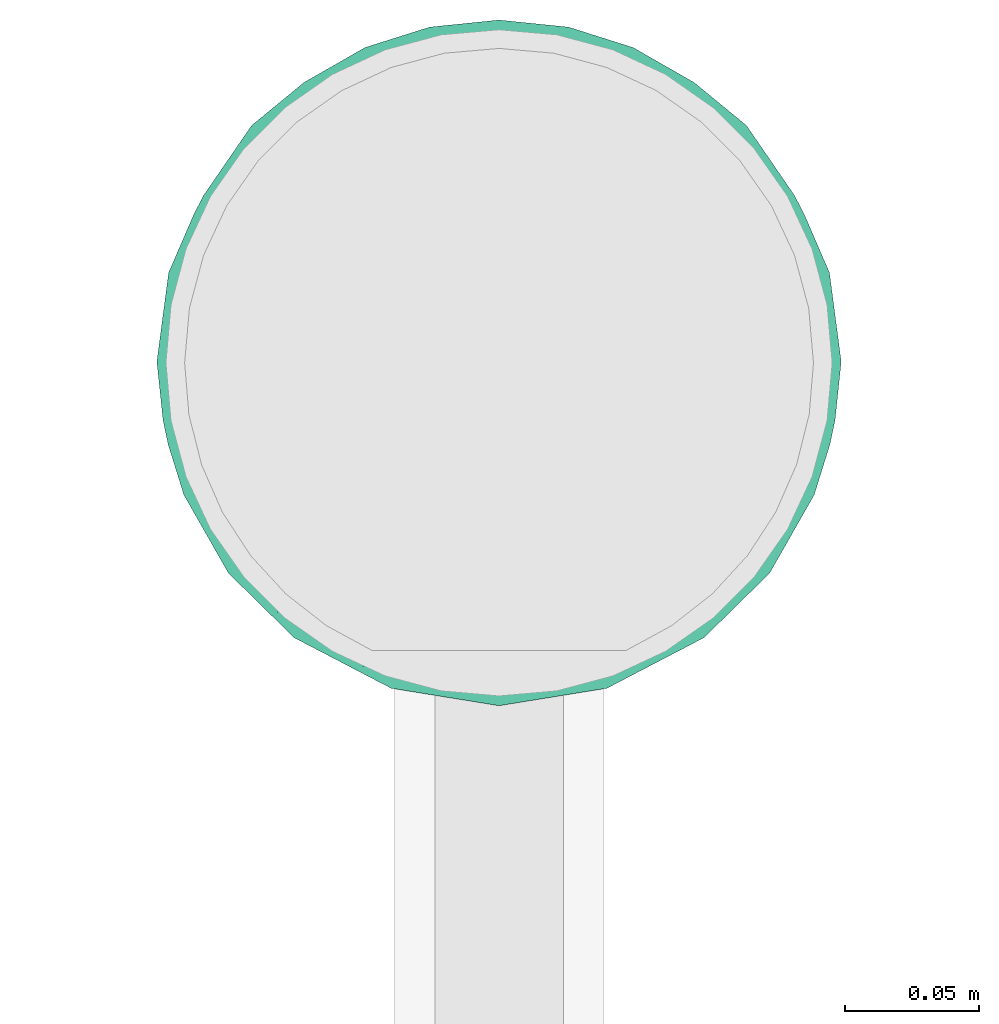
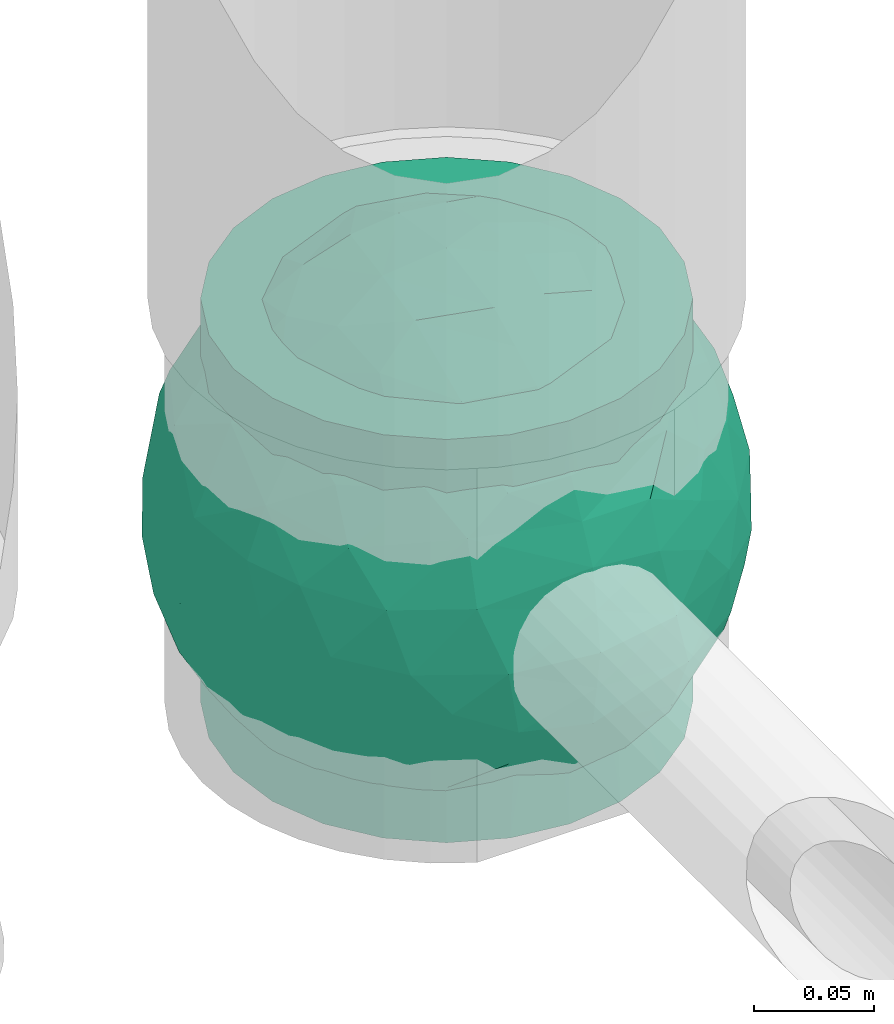
# One storey, part 34 of 39: 1 flow fitting.
"""IFC2X3 building model written with IfcOpenShell, lengths in millimetres."""

from ifc_helpers import new_model, entity, si_unit, converted_unit, derived_unit, direction, frame, origin, place, context, subcontext, project, spatial, faceted_brep, source, transform, mapped, material, material_list, type_object, type_shapes, element, save


model = new_model("IFC2X3")

# Units and contexts
model_context = context("Model", 3, precision=0.01, world=origin(), true_north=direction((6.12303176911189e-17, 1.0)))
body_context = subcontext(model_context, "Body", "Model", "MODEL_VIEW")
ifc_project = project(units=[si_unit("LENGTHUNIT", "METRE", prefix="MILLI"), si_unit("AREAUNIT", "SQUARE_METRE"), si_unit("VOLUMEUNIT", "CUBIC_METRE"), converted_unit("PLANEANGLEUNIT", "DEGREE", entity("IfcRatioMeasure", 0.0174532925199433), si_unit("PLANEANGLEUNIT", "RADIAN"), dimensions=[0, 0, 0, 0, 0, 0, 0]), si_unit("MASSUNIT", "GRAM", prefix="KILO"), derived_unit("MASSDENSITYUNIT", [(si_unit("MASSUNIT", "GRAM", prefix="KILO"), 1), (si_unit("LENGTHUNIT", "METRE"), -3)]), derived_unit("MOMENTOFINERTIAUNIT", [(si_unit("LENGTHUNIT", "METRE"), 4)]), si_unit("TIMEUNIT", "SECOND"), si_unit("FREQUENCYUNIT", "HERTZ"), si_unit("THERMODYNAMICTEMPERATUREUNIT", "DEGREE_CELSIUS"), derived_unit("THERMALTRANSMITTANCEUNIT", [(si_unit("MASSUNIT", "GRAM", prefix="KILO"), 1), (si_unit("THERMODYNAMICTEMPERATUREUNIT", "KELVIN"), -1), (si_unit("TIMEUNIT", "SECOND"), -3)]), derived_unit("VOLUMETRICFLOWRATEUNIT", [(si_unit("LENGTHUNIT", "METRE"), 3), (si_unit("TIMEUNIT", "SECOND"), -1)]), derived_unit("MASSFLOWRATEUNIT", [(si_unit("MASSUNIT", "GRAM", prefix="KILO"), 1), (si_unit("TIMEUNIT", "SECOND"), -1)]), derived_unit("ROTATIONALFREQUENCYUNIT", [(si_unit("TIMEUNIT", "SECOND"), -1)]), si_unit("ELECTRICCURRENTUNIT", "AMPERE"), si_unit("ELECTRICVOLTAGEUNIT", "VOLT"), si_unit("POWERUNIT", "WATT"), si_unit("FORCEUNIT", "NEWTON", prefix="KILO"), si_unit("ILLUMINANCEUNIT", "LUX"), si_unit("LUMINOUSFLUXUNIT", "LUMEN"), si_unit("LUMINOUSINTENSITYUNIT", "CANDELA"), derived_unit("USERDEFINED", [(si_unit("MASSUNIT", "GRAM", prefix="KILO"), -1), (si_unit("LENGTHUNIT", "METRE"), -2), (si_unit("TIMEUNIT", "SECOND"), 3), (si_unit("LUMINOUSFLUXUNIT", "LUMEN"), 1)]), derived_unit("LINEARVELOCITYUNIT", [(si_unit("LENGTHUNIT", "METRE"), 1), (si_unit("TIMEUNIT", "SECOND"), -1)]), si_unit("PRESSUREUNIT", "PASCAL"), derived_unit("USERDEFINED", [(si_unit("LENGTHUNIT", "METRE"), -2), (si_unit("MASSUNIT", "GRAM", prefix="KILO"), 1), (si_unit("TIMEUNIT", "SECOND"), -2)]), derived_unit("LINEARFORCEUNIT", [(si_unit("MASSUNIT", "GRAM", prefix="KILO"), 1), (si_unit("LENGTHUNIT", "METRE"), 1), (si_unit("TIMEUNIT", "SECOND"), -2), (si_unit("LENGTHUNIT", "METRE"), -1)]), derived_unit("PLANARFORCEUNIT", [(si_unit("MASSUNIT", "GRAM", prefix="KILO"), 1), (si_unit("LENGTHUNIT", "METRE"), 1), (si_unit("TIMEUNIT", "SECOND"), -2), (si_unit("LENGTHUNIT", "METRE"), -2)])], contexts=[model_context])

# Site, building, storey
site_placement = place(None, origin())
site = spatial("IfcSite", under=ifc_project, at=site_placement, CompositionType="ELEMENT")
building_placement = place(site_placement, origin())
building = spatial("IfcBuilding", under=site, at=building_placement, CompositionType="ELEMENT")
storey_placement = place(building_placement, frame((0.0, 0.0, 24000.0)))
storey = spatial("IfcBuildingStorey", under=building, at=storey_placement, Name="07", CompositionType="ELEMENT", Elevation=24000.0)

# Flow fitting
ifc_material_1 = material()
ifc_material_2 = material(Name="ADSK_")
ifc_material_list = material_list([ifc_material_1, ifc_material_2])
pipe_fitting_type = type_object("IfcPipeFittingType", Name="ADSK_2", PredefinedType="NOTDEFINED", material=ifc_material_list)
shared_shape = source(origin(), body_context, "Body", "Brep", [
    faceted_brep([(-102.5, 0.0, -102.5), (-102.5, -26.53, -99.01), (-102.5, -51.25, -88.77), (-102.5, -72.48, -72.48), (-102.5, -88.77, -51.25), (-102.5, -99.01, -26.53), (-102.5, -102.5, 0.0), (-102.5, -99.01, 26.53), (-102.5, -88.77, 51.25), (-102.5, -72.48, 72.48), (-102.5, -51.25, 88.77), (-102.5, -26.53, 99.01), (-102.5, 0.0, 102.5), (-102.5, 26.53, 99.01), (-102.5, 51.25, 88.77), (-102.5, 72.48, 72.48), (-102.5, 88.77, 51.25), (-102.5, 99.01, 26.53), (-102.5, 102.5, 0.0), (-102.5, 99.01, -26.53), (-102.5, 88.77, -51.25), (-102.5, 72.48, -72.48), (-102.5, 51.25, -88.77), (-102.5, 26.53, -99.01), (102.5, 26.53, -99.01), (102.5, 51.25, -88.77), (102.5, 72.48, -72.48), (102.5, 88.77, -51.25), (102.5, 99.01, -26.53), (102.5, 102.5, 0.0), (102.5, 99.01, 26.53), (102.5, 88.77, 51.25), (102.5, 72.48, 72.48), (102.5, 51.25, 88.77), (102.5, 26.53, 99.01), (102.5, 0.0, 102.5), (102.5, -26.53, 99.01), (102.5, -51.25, 88.77), (102.5, -72.48, 72.48), (102.5, -88.77, 51.25), (102.5, -99.01, 26.53), (102.5, -102.5, 0.0), (102.5, -99.01, -26.53), (102.5, -88.77, -51.25), (102.5, -72.48, -72.48), (102.5, -51.25, -88.77), (102.5, -26.53, -99.01), (102.5, 0.0, -102.5), (21.14, -102.21, 7.71), (21.82, -102.35, 3.86), (22.5, -102.5, 0.0), (17.23, -101.47, 14.47), (3.91, -100.08, 22.16), (7.59, -100.35, 20.82), (11.26, -100.63, 19.48), (-21.14, -102.21, 7.71), (-17.24, -101.47, 14.46), (-22.5, -102.5, 0.0), (-21.82, -102.35, 3.85), (-11.27, -100.63, 19.48), (-7.59, -100.35, 20.82), (-3.92, -100.08, 22.16), (0.0, -100.08, 22.16), (3.91, -100.08, -22.16), (11.26, -100.63, -19.48), (7.59, -100.35, -20.82), (21.82, -102.35, -3.86), (21.14, -102.21, -7.71), (17.23, -101.47, -14.47), (0.0, -100.08, -22.16), (-3.92, -100.08, -22.16), (-7.59, -100.35, -20.82), (-11.27, -100.63, -19.48), (-17.24, -101.47, -14.46), (-21.14, -102.21, -7.71), (-21.82, -102.35, -3.85), (0.0, -107.5, -22.5), (5.82, -107.5, -21.73), (11.25, -107.5, -19.49), (15.91, -107.5, -15.91), (19.49, -107.5, -11.25), (21.73, -107.5, -5.82), (22.5, -107.5, 0.0), (21.73, -107.5, 5.82), (19.49, -107.5, 11.25), (15.91, -107.5, 15.91), (11.25, -107.5, 19.49), (5.82, -107.5, 21.73), (0.0, -107.5, 22.5), (-5.82, -107.5, 21.73), (-11.25, -107.5, 19.49), (-15.91, -107.5, 15.91), (-19.49, -107.5, 11.25), (-21.73, -107.5, 5.82), (-22.5, -107.5, 0.0), (-21.73, -107.5, -5.82), (-19.49, -107.5, -11.25), (-15.91, -107.5, -15.91), (-11.25, -107.5, -19.49), (-5.82, -107.5, -21.73)], [[[0, 1, 2, 3, 4, 5, 6, 7, 8, 9, 10, 11, 12, 13, 14, 15, 16, 17, 18, 19, 20, 21, 22, 23]], [[24, 25, 26, 27, 28, 29, 30, 31, 32, 33, 34, 35, 36, 37, 38, 39, 40, 41, 42, 43, 44, 45, 46, 47]], [[41, 48, 49, 50]], [[51, 48, 41]], [[41, 40, 51]], [[52, 39, 8]], [[40, 52, 53, 54]], [[40, 54, 51]], [[52, 40, 39]], [[39, 38, 9, 8]], [[55, 56, 6]], [[6, 57, 58, 55]], [[56, 7, 6]], [[7, 59, 60, 61]], [[61, 8, 7]], [[8, 61, 62, 52]], [[59, 7, 56]], [[38, 37, 10, 9]], [[12, 11, 36, 35]], [[11, 10, 37, 36]], [[13, 12, 35, 34]], [[31, 30, 17, 16]], [[15, 14, 33, 32]], [[16, 15, 32, 31]], [[34, 33, 14, 13]], [[18, 17, 30, 29]], [[20, 19, 28, 27]], [[19, 18, 29, 28]], [[21, 20, 27, 26]], [[47, 46, 1, 0]], [[23, 22, 25, 24]], [[0, 23, 24, 47]], [[26, 25, 22, 21]], [[2, 1, 46, 45]], [[45, 44, 3, 2]], [[43, 42, 63]], [[4, 43, 63]], [[43, 4, 3, 44]], [[42, 64, 65, 63]], [[41, 50, 66, 67]], [[64, 42, 68]], [[67, 68, 41]], [[68, 42, 41]], [[4, 63, 69, 70]], [[5, 4, 70]], [[5, 70, 71, 72]], [[73, 6, 5]], [[6, 74, 75, 57]], [[74, 6, 73]], [[73, 5, 72]], [[76, 77, 78, 79, 80, 81, 82, 83, 84, 85, 86, 87, 88, 89, 90, 91, 92, 93, 94, 95, 96, 97, 98, 99]], [[93, 58, 94]], [[56, 92, 91]], [[93, 92, 55]], [[91, 90, 59]], [[93, 55, 58]], [[58, 57, 94]], [[55, 92, 56]], [[60, 59, 90]], [[89, 61, 60]], [[59, 56, 91]], [[88, 52, 62, 61]], [[86, 53, 87]], [[49, 48, 83]], [[52, 88, 87]], [[53, 86, 54]], [[51, 85, 84]], [[86, 85, 54]], [[48, 84, 83]], [[85, 51, 54]], [[52, 87, 53]], [[49, 82, 50]], [[82, 49, 83]], [[48, 51, 84]], [[60, 90, 89]], [[88, 61, 89]], [[81, 66, 82]], [[68, 80, 79]], [[81, 80, 67]], [[79, 78, 64]], [[81, 67, 66]], [[66, 50, 82]], [[67, 80, 68]], [[65, 64, 78]], [[77, 63, 65]], [[64, 68, 79]], [[76, 70, 69, 63]], [[98, 71, 99]], [[75, 74, 95]], [[76, 99, 70]], [[71, 98, 72]], [[73, 97, 96]], [[98, 97, 72]], [[74, 96, 95]], [[97, 73, 72]], [[70, 99, 71]], [[75, 94, 57]], [[94, 75, 95]], [[74, 73, 96]], [[65, 78, 77]], [[76, 63, 77]]]),
    faceted_brep([(103.66, -75.31, 0.0), (112.67, -37.71, -47.95), (119.68, -38.65, -24.46), (100.39, 25.74, -75.33), (105.47, -0.45, -72.74), (87.71, 0.0, -93.4), (121.85, -39.59, 0.0), (112.75, -57.45, 0.0), (117.35, 10.45, -50.35), (111.96, 45.77, -42.26), (67.62, 97.03, -49.29), (83.92, 80.91, -53.17), (73.94, 63.55, -83.12), (115.42, -13.68, -53.92), (123.96, -14.86, -28.8), (96.32, -72.86, -42.79), (89.48, -89.48, 0.0), (75.31, -103.66, 0.0), (89.48, 89.48, 0.0), (103.01, 69.91, -30.31), (-29.36, -93.22, -82.85), (-59.51, -102.32, -49.05), (-52.27, -74.51, -90.18), (125.29, 12.16, -23.88), (128.13, 0.0, 0.0), (112.75, 57.45, 0.0), (119.72, 39.01, -23.71), (77.61, 29.8, -97.5), (-119.71, 38.94, -23.86), (-124.41, 0.58, -30.62), (-121.85, 39.59, 0.0), (89.61, -41.49, -81.64), (4.38, 117.84, -50.1), (32.72, 118.23, -36.99), (11.16, 104.77, -72.9), (-112.75, 57.45, 0.0), (-103.66, 75.31, 0.0), (50.37, 71.59, -93.56), (35.32, 103.01, -67.51), (50.37, -71.59, -93.56), (67.49, -50.53, -96.47), (82.04, -68.31, -70.84), (-75.31, -103.66, 0.0), (-89.48, -89.48, 0.0), (-89.39, -85.39, -33.7), (-35.73, -2.64, -123.01), (-75.31, 0.0, -103.66), (-54.88, 35.9, -110.07), (-120.43, -29.42, -32.37), (-114.01, -8.85, -57.79), (-108.35, -40.08, -55.41), (-52.27, 74.51, -90.18), (-73.84, 91.26, -51.34), (-46.3, 104.5, -57.91), (-32.09, -62.84, -106.95), (-57.65, -36.81, -108.34), (-33.38, -37.89, -117.75), (-76.97, -84.04, -58.56), (-73.72, -58.24, -87.12), (-18.02, 55.57, -114.03), (-121.85, -39.59, 0.0), (-29.91, 89.89, -86.26), (-76.68, 66.43, -78.25), (-102.63, 37.68, -66.81), (-96.32, 72.91, -42.68), (-88.67, 39.81, -83.47), (32.42, -10.97, -123.47), (54.26, -1.64, -116.06), (53.15, -26.46, -113.54), (-112.96, 38.28, -46.81), (50.79, 23.01, -115.36), (55.04, 48.17, -105.19), (20.5, -110.73, -61.11), (0.77, -121.6, -40.35), (0.05, -102.71, -76.6), (-31.11, -113.42, -50.84), (-86.58, -32.21, -88.78), (-89.48, 89.48, 0.0), (-75.31, 103.66, 0.0), (-107.5, 16.33, -67.78), (-93.17, 17.31, -86.23), (75.07, -27.21, -100.21), (-93.37, -62.04, -62.04), (-97.29, -5.48, -83.19), (-55.39, 111.83, -29.03), (-57.45, 112.75, 0.0), (-39.59, 121.85, 0.0), (-35.64, 118.01, -34.93), (-20.19, 109.53, -63.34), (39.59, 121.85, 0.0), (51.67, 110.16, -40.12), (-16.88, 120.75, -39.38), (-0.57, 125.47, -25.96), (17.69, 62.69, -110.33), (-0.59, 88.7, -92.46), (26.41, 85.02, -92.15), (-24.43, 26.45, -122.96), (8.05, 0.42, -127.87), (13.92, -30.45, -123.67), (-13.74, -21.43, -125.57), (45.36, -49.83, -108.98), (-3.24, -78.6, -101.13), (55.42, -90.6, -71.66), (-19.8, -124.99, 0.0), (5.84, 33.69, -123.48), (72.43, -91.39, -53.08), (55.5, -110.31, -34.18), (57.45, -112.75, 0.0), (39.59, -121.85, 0.0), (19.8, -124.99, 0.0), (0.0, -128.13, 0.0), (23.43, -89.6, -88.53), (34.27, -118.7, -33.96), (41.3, -104.28, -61.93), (-39.59, -121.85, 0.0), (-57.45, -112.75, 0.0), (21.97, -58.98, -111.6), (31.58, 41.12, -117.16), (19.8, 124.99, 0.0), (57.45, 112.75, 0.0), (93.95, 56.43, -66.37), (-74.35, -100.36, -28.55), (-103.1, -68.8, -32.46), (-112.75, -57.45, 0.0), (-103.66, -75.31, 0.0), (-128.12, 0.0, 0.0), (-10.48, -49.37, -117.77), (121.85, 39.59, 0.0), (103.66, 75.31, 0.0), (75.31, 103.66, 0.0), (-19.8, 124.99, 0.0), (0.0, 128.12, 0.0), (-112.67, -37.71, 47.95), (-119.68, -38.65, 24.46), (-100.39, 25.74, 75.33), (-105.47, -0.45, 72.74), (-87.71, 0.0, 93.4), (-117.35, 10.45, 50.35), (-111.96, 45.77, 42.26), (-67.62, 97.03, 49.29), (-83.92, 80.91, 53.17), (-73.94, 63.55, 83.12), (-115.42, -13.68, 53.92), (-123.96, -14.86, 28.8), (-96.32, -72.86, 42.79), (-103.01, 69.91, 30.31), (29.36, -93.22, 82.85), (59.51, -102.32, 49.05), (52.27, -74.51, 90.18), (-125.29, 12.16, 23.88), (-119.72, 39.01, 23.71), (-77.61, 29.8, 97.5), (119.71, 38.94, 23.86), (124.41, 0.58, 30.62), (-89.61, -41.49, 81.64), (-4.38, 117.84, 50.1), (-32.72, 118.23, 36.99), (-11.16, 104.77, 72.9), (-50.37, 71.59, 93.56), (-35.32, 103.01, 67.51), (-50.37, -71.59, 93.56), (-67.49, -50.53, 96.47), (-82.04, -68.31, 70.84), (89.39, -85.39, 33.7), (35.73, -2.64, 123.01), (75.31, 0.0, 103.66), (54.88, 35.9, 110.07), (120.43, -29.42, 32.37), (114.01, -8.85, 57.79), (108.35, -40.08, 55.41), (52.27, 74.51, 90.18), (73.84, 91.26, 51.34), (46.3, 104.5, 57.91), (32.09, -62.84, 106.95), (57.65, -36.81, 108.34), (33.38, -37.89, 117.75), (76.97, -84.04, 58.56), (73.72, -58.24, 87.12), (18.02, 55.57, 114.03), (29.91, 89.89, 86.26), (76.68, 66.43, 78.25), (102.63, 37.68, 66.81), (96.32, 72.91, 42.68), (88.67, 39.81, 83.47), (-32.42, -10.97, 123.47), (-54.26, -1.64, 116.06), (-53.15, -26.46, 113.54), (112.96, 38.28, 46.81), (-50.79, 23.01, 115.36), (-55.04, 48.17, 105.19), (-20.5, -110.73, 61.11), (-0.77, -121.6, 40.35), (-0.05, -102.71, 76.6), (31.11, -113.42, 50.84), (86.58, -32.21, 88.78), (107.5, 16.33, 67.78), (93.17, 17.31, 86.23), (-75.07, -27.21, 100.21), (93.37, -62.04, 62.04), (103.1, -68.8, 32.46), (97.29, -5.48, 83.19), (55.39, 111.83, 29.03), (35.64, 118.01, 34.93), (20.19, 109.53, 63.34), (-51.67, 110.16, 40.12), (16.88, 120.75, 39.38), (0.57, 125.47, 25.96), (-17.69, 62.69, 110.33), (0.59, 88.7, 92.46), (-26.41, 85.02, 92.15), (24.43, 26.45, 122.96), (-8.05, 0.42, 127.87), (-13.92, -30.45, 123.67), (13.74, -21.43, 125.57), (-45.36, -49.83, 108.98), (3.24, -78.6, 101.13), (-55.42, -90.6, 71.66), (-5.84, 33.69, 123.48), (-72.43, -91.39, 53.08), (-55.5, -110.31, 34.18), (-23.43, -89.6, 88.53), (-34.27, -118.7, 33.96), (-41.3, -104.28, 61.93), (-21.97, -58.98, 111.6), (-31.58, 41.12, 117.16), (-93.95, 56.43, 66.37), (74.35, -100.36, 28.55), (10.48, -49.37, 117.77)], [[[0, 1, 2]], [[3, 4, 5]], [[2, 6, 7, 0]], [[8, 3, 9]], [[10, 11, 12]], [[13, 14, 2]], [[15, 0, 16, 17]], [[18, 19, 11]], [[20, 21, 22]], [[23, 24, 14]], [[25, 26, 9]], [[3, 5, 27]], [[28, 29, 30]], [[15, 31, 1]], [[32, 33, 34]], [[28, 30, 35, 36]], [[10, 37, 38]], [[39, 40, 41]], [[42, 43, 44]], [[45, 46, 47]], [[48, 49, 50]], [[51, 52, 53]], [[54, 55, 56]], [[22, 57, 58]], [[59, 47, 51]], [[60, 29, 48]], [[6, 14, 24]], [[53, 61, 51]], [[48, 29, 49]], [[51, 62, 52]], [[63, 64, 65]], [[66, 67, 68]], [[28, 36, 69]], [[27, 70, 71]], [[72, 73, 74]], [[73, 75, 74]], [[22, 54, 20]], [[76, 46, 55]], [[64, 36, 77, 78]], [[79, 63, 80]], [[81, 31, 40]], [[47, 46, 65]], [[57, 44, 82]], [[76, 83, 46]], [[52, 64, 78]], [[83, 79, 80]], [[62, 64, 52]], [[65, 62, 47]], [[84, 85, 86]], [[84, 52, 85]], [[87, 88, 53]], [[89, 90, 33]], [[91, 92, 32]], [[93, 59, 94]], [[61, 88, 94]], [[87, 91, 88]], [[37, 93, 95]], [[51, 61, 59]], [[59, 96, 47]], [[97, 98, 99]], [[55, 46, 45]], [[68, 100, 98]], [[20, 101, 74]], [[39, 41, 102]], [[75, 73, 103]], [[94, 95, 93]], [[59, 104, 96]], [[45, 99, 56]], [[55, 58, 76]], [[105, 15, 17]], [[31, 5, 4]], [[106, 107, 108]], [[106, 105, 107]], [[109, 110, 73]], [[111, 74, 101]], [[112, 108, 109]], [[73, 110, 103]], [[112, 72, 113]], [[103, 114, 75]], [[21, 75, 114]], [[20, 74, 75]], [[21, 114, 115]], [[58, 57, 82]], [[41, 31, 15]], [[31, 41, 40]], [[39, 111, 116]], [[68, 98, 66]], [[93, 104, 59]], [[70, 117, 71]], [[32, 118, 33]], [[119, 90, 89]], [[90, 10, 38]], [[12, 11, 120]], [[58, 55, 22]], [[76, 82, 50]], [[57, 22, 21]], [[82, 76, 58]], [[21, 115, 121]], [[121, 44, 57]], [[122, 123, 48]], [[122, 43, 124]], [[50, 82, 122]], [[123, 122, 124]], [[50, 49, 83]], [[43, 122, 44]], [[82, 44, 122]], [[50, 122, 48]], [[29, 60, 125]], [[30, 29, 125]], [[79, 29, 69]], [[48, 123, 60]], [[117, 37, 71]], [[117, 97, 104]], [[117, 104, 93]], [[96, 97, 45]], [[97, 96, 104]], [[47, 96, 45]], [[52, 78, 85]], [[21, 20, 75]], [[55, 54, 22]], [[116, 101, 126]], [[111, 113, 72]], [[98, 116, 126]], [[40, 100, 68]], [[116, 111, 101]], [[102, 111, 39]], [[99, 98, 126]], [[98, 97, 66]], [[56, 99, 126]], [[97, 99, 45]], [[56, 126, 54]], [[45, 56, 55]], [[126, 101, 54]], [[20, 54, 101]], [[97, 70, 66]], [[67, 66, 70]], [[27, 67, 70]], [[81, 67, 5]], [[50, 83, 76]], [[83, 49, 79]], [[29, 79, 49]], [[63, 79, 69]], [[65, 46, 80]], [[46, 83, 80]], [[121, 115, 42]], [[6, 2, 14]], [[23, 14, 8]], [[26, 8, 9]], [[127, 24, 23]], [[37, 117, 93]], [[97, 117, 70]], [[37, 12, 71]], [[27, 5, 67]], [[12, 27, 71]], [[3, 27, 120]], [[10, 12, 37]], [[27, 12, 120]], [[9, 3, 120]], [[4, 3, 8]], [[19, 18, 128]], [[19, 128, 9]], [[10, 129, 11]], [[11, 129, 18]], [[127, 26, 25]], [[9, 120, 19]], [[11, 19, 120]], [[8, 13, 4]], [[31, 4, 1]], [[14, 13, 8]], [[1, 4, 13]], [[105, 17, 107]], [[112, 106, 108]], [[106, 113, 102]], [[92, 118, 32]], [[64, 63, 69]], [[80, 63, 65]], [[1, 0, 15]], [[2, 1, 13]], [[69, 36, 64]], [[29, 28, 69]], [[47, 62, 51]], [[64, 62, 65]], [[88, 61, 53]], [[59, 61, 94]], [[84, 87, 53]], [[88, 32, 34]], [[86, 130, 87]], [[88, 91, 32]], [[87, 130, 91]], [[92, 130, 131]], [[130, 92, 91]], [[118, 92, 131]], [[106, 102, 105]], [[111, 102, 113]], [[73, 112, 109]], [[106, 112, 113]], [[73, 72, 112]], [[111, 72, 74]], [[15, 105, 41]], [[41, 105, 102]], [[100, 40, 39]], [[81, 40, 68]], [[39, 116, 100]], [[98, 100, 116]], [[67, 81, 68]], [[5, 31, 81]], [[95, 34, 38]], [[88, 34, 94]], [[33, 90, 38]], [[90, 119, 10]], [[33, 38, 34]], [[129, 10, 119]], [[89, 33, 118]], [[34, 95, 94]], [[37, 95, 38]], [[87, 84, 86]], [[52, 84, 53]], [[44, 121, 42]], [[21, 121, 57]], [[9, 128, 25]], [[127, 23, 26]], [[8, 26, 23]], [[124, 132, 133]], [[134, 135, 136]], [[133, 60, 123, 124]], [[137, 134, 138]], [[139, 140, 141]], [[142, 143, 133]], [[144, 124, 43, 42]], [[77, 145, 140]], [[146, 147, 148]], [[149, 125, 143]], [[35, 150, 138]], [[134, 136, 151]], [[152, 153, 127]], [[144, 154, 132]], [[155, 156, 157]], [[152, 127, 25, 128]], [[139, 158, 159]], [[160, 161, 162]], [[17, 16, 163]], [[164, 165, 166]], [[167, 168, 169]], [[170, 171, 172]], [[173, 174, 175]], [[148, 176, 177]], [[178, 166, 170]], [[6, 153, 167]], [[60, 143, 125]], [[172, 179, 170]], [[167, 153, 168]], [[170, 180, 171]], [[181, 182, 183]], [[184, 185, 186]], [[152, 128, 187]], [[151, 188, 189]], [[190, 191, 192]], [[191, 193, 192]], [[148, 173, 146]], [[194, 165, 174]], [[182, 128, 18, 129]], [[195, 181, 196]], [[197, 154, 161]], [[166, 165, 183]], [[169, 198, 199]], [[194, 200, 165]], [[171, 182, 129]], [[200, 195, 196]], [[180, 182, 171]], [[183, 180, 166]], [[201, 119, 89]], [[201, 171, 119]], [[202, 203, 172]], [[86, 204, 156]], [[205, 206, 155]], [[207, 178, 208]], [[179, 203, 208]], [[202, 205, 203]], [[158, 207, 209]], [[170, 179, 178]], [[178, 210, 166]], [[211, 212, 213]], [[174, 165, 164]], [[186, 214, 212]], [[146, 215, 192]], [[160, 162, 216]], [[193, 191, 109]], [[208, 209, 207]], [[178, 217, 210]], [[164, 213, 175]], [[174, 177, 194]], [[218, 144, 42]], [[154, 136, 135]], [[219, 115, 114]], [[219, 218, 115]], [[103, 110, 191]], [[220, 192, 215]], [[221, 114, 103]], [[191, 110, 109]], [[221, 190, 222]], [[109, 108, 193]], [[147, 193, 108]], [[146, 192, 193]], [[147, 108, 107]], [[177, 176, 198]], [[162, 154, 144]], [[154, 162, 161]], [[160, 220, 223]], [[186, 212, 184]], [[207, 217, 178]], [[188, 224, 189]], [[155, 130, 156]], [[85, 204, 86]], [[204, 139, 159]], [[141, 140, 225]], [[177, 174, 148]], [[194, 198, 169]], [[176, 148, 147]], [[198, 194, 177]], [[147, 107, 226]], [[226, 163, 176]], [[199, 7, 167]], [[0, 199, 16]], [[163, 198, 176]], [[7, 199, 0]], [[169, 168, 200]], [[16, 199, 163]], [[198, 163, 199]], [[169, 199, 167]], [[153, 6, 24]], [[127, 153, 24]], [[195, 153, 187]], [[167, 7, 6]], [[224, 158, 189]], [[224, 211, 217]], [[224, 217, 207]], [[210, 211, 164]], [[211, 210, 217]], [[166, 210, 164]], [[171, 129, 119]], [[147, 146, 193]], [[174, 173, 148]], [[223, 215, 227]], [[220, 222, 190]], [[212, 223, 227]], [[161, 214, 186]], [[223, 220, 215]], [[216, 220, 160]], [[213, 212, 227]], [[212, 211, 184]], [[175, 213, 227]], [[211, 213, 164]], [[175, 227, 173]], [[164, 175, 174]], [[227, 215, 173]], [[146, 173, 215]], [[211, 188, 184]], [[185, 184, 188]], [[151, 185, 188]], [[197, 185, 136]], [[169, 200, 194]], [[200, 168, 195]], [[153, 195, 168]], [[181, 195, 187]], [[183, 165, 196]], [[165, 200, 196]], [[226, 107, 17]], [[60, 133, 143]], [[149, 143, 137]], [[150, 137, 138]], [[30, 125, 149]], [[158, 224, 207]], [[211, 224, 188]], [[158, 141, 189]], [[151, 136, 185]], [[141, 151, 189]], [[134, 151, 225]], [[139, 141, 158]], [[151, 141, 225]], [[138, 134, 225]], [[135, 134, 137]], [[145, 77, 36]], [[145, 36, 138]], [[139, 78, 140]], [[140, 78, 77]], [[30, 150, 35]], [[138, 225, 145]], [[140, 145, 225]], [[137, 142, 135]], [[154, 135, 132]], [[143, 142, 137]], [[132, 135, 142]], [[218, 42, 115]], [[221, 219, 114]], [[219, 222, 216]], [[206, 130, 155]], [[182, 181, 187]], [[196, 181, 183]], [[132, 124, 144]], [[133, 132, 142]], [[187, 128, 182]], [[153, 152, 187]], [[166, 180, 170]], [[182, 180, 183]], [[203, 179, 172]], [[178, 179, 208]], [[201, 202, 172]], [[203, 155, 157]], [[89, 118, 202]], [[203, 205, 155]], [[202, 118, 205]], [[206, 118, 131]], [[118, 206, 205]], [[130, 206, 131]], [[219, 216, 218]], [[220, 216, 222]], [[191, 221, 103]], [[219, 221, 222]], [[191, 190, 221]], [[220, 190, 192]], [[144, 218, 162]], [[162, 218, 216]], [[214, 161, 160]], [[197, 161, 186]], [[160, 223, 214]], [[212, 214, 223]], [[185, 197, 186]], [[136, 154, 197]], [[209, 157, 159]], [[203, 157, 208]], [[156, 204, 159]], [[204, 85, 139]], [[156, 159, 157]], [[78, 139, 85]], [[86, 156, 130]], [[157, 209, 208]], [[158, 209, 159]], [[202, 201, 89]], [[171, 201, 172]], [[163, 226, 17]], [[147, 226, 176]], [[138, 36, 35]], [[30, 149, 150]], [[137, 150, 149]]]),
])
type_shapes(pipe_fitting_type, [shared_shape])
flow_fitting_placement = place(storey_placement, frame((31430.0, 10950.0, 2660.0), z_axis=(-1.0, 0.0, 0.0), x_axis=(0.0, 0.0, 1.0)))
element("IfcFlowFitting", 1, at=flow_fitting_placement, inside=storey, type_object=pipe_fitting_type, material=ifc_material_list, Name="ADSK_2", ObjectType="ADSK_2", context=body_context, shape_type="MappedRepresentation", body=[
    mapped(shared_shape, transform((0.0, 0.0, 0.0), scale=1.0)),
])

save(model, "model.ifc")
